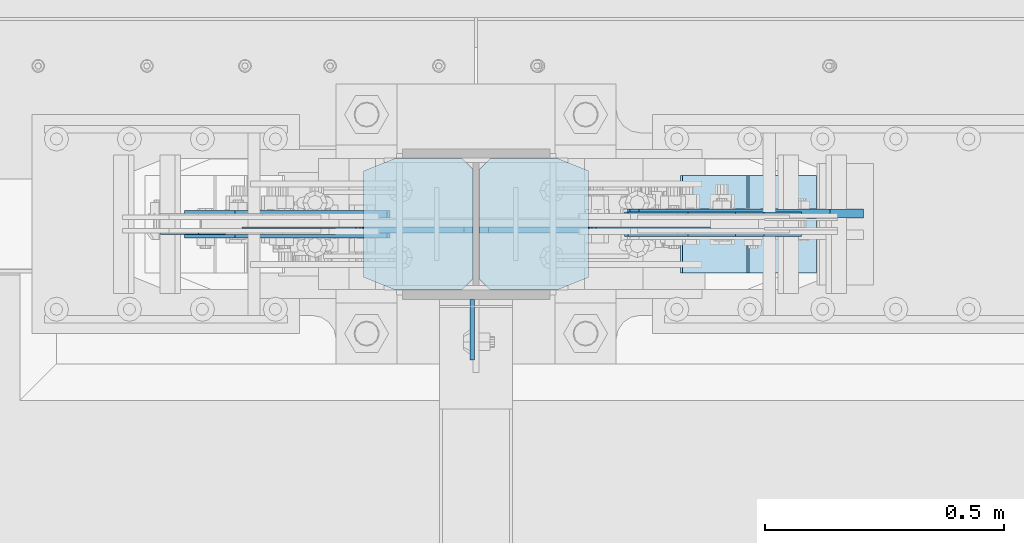
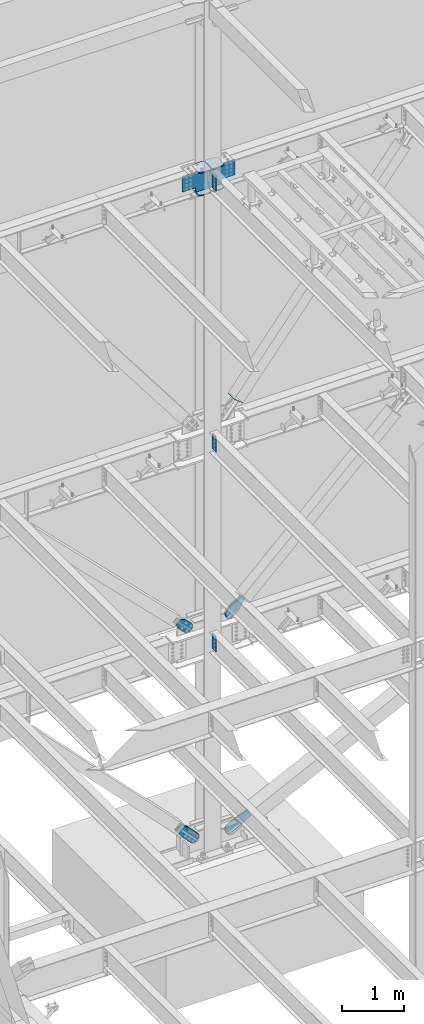
# One storey, part 1073 of 1179: 17 plates, 9 elements without a shape of their own.
"""IFC2X3 building model written with IfcOpenShell, lengths in millimetres."""

from ifc_helpers import new_model, si_unit, frame, origin_with_axes, place, context, subcontext, project, spatial, faceted_brep, material, type_object, element, aggregate, save


model = new_model("IFC2X3")

# Units and contexts
model_context = context("Model", 3, precision=1e-05, world=origin_with_axes())
body_context = subcontext(model_context, "Body", "Model", "MODEL_VIEW")
ifc_project = project(units=[si_unit("LENGTHUNIT", "METRE", prefix="MILLI"), si_unit("AREAUNIT", "SQUARE_METRE"), si_unit("VOLUMEUNIT", "CUBIC_METRE"), si_unit("MASSUNIT", "GRAM", prefix="KILO"), si_unit("TIMEUNIT", "SECOND"), si_unit("PLANEANGLEUNIT", "RADIAN"), si_unit("SOLIDANGLEUNIT", "STERADIAN"), si_unit("THERMODYNAMICTEMPERATUREUNIT", "DEGREE_CELSIUS"), si_unit("LUMINOUSINTENSITYUNIT", "LUMEN")], contexts=[model_context])

# Site, building, storey
site_placement = place(None, origin_with_axes())
site = spatial("IfcSite", under=ifc_project, at=site_placement, CompositionType="ELEMENT")
building_placement = place(site_placement, origin_with_axes())
building = spatial("IfcBuilding", under=site, at=building_placement, Name="Undefined", CompositionType="ELEMENT")
storey_placement = place(building_placement, origin_with_axes())
storey = spatial("IfcBuildingStorey", under=building, at=storey_placement, Name="Undefined", CompositionType="ELEMENT", Elevation=0.0)

# Assembly, plates
assembly_1_placement = place(storey_placement, origin_with_axes())
assembly_1 = element("IfcElementAssembly", 1, at=assembly_1_placement, inside=storey, Name="COLUMN", AssemblyPlace="NOTDEFINED", PredefinedType="RIGID_FRAME")
ifc_material_1 = material(Name="STEEL/A36")
plate_type_1 = type_object("IfcPlateType", PredefinedType="NOTDEFINED")
plate_1_placement = place(assembly_1_placement, frame((8272.4625, 41041.6375, 13080.9999983942), z_axis=(0.0, -1.0, 0.0), x_axis=(0.0, 0.0, -1.0)))
plate_1 = element("IfcPlate", 2, at=plate_1_placement, type_object=plate_type_1, material=ifc_material_1, Name="PLATE", context=body_context, shape_type="Brep", body=[
    faceted_brep([(0.0, -4.76249999999709, 0.0), (0.0, -4.76249999999709, 127.0), (0.0, 4.76249999999709, 127.0), (0.0, 4.76249999999709, 0.0), (304.799999999999, -4.76249999999982, 127.0), (304.799999999999, 4.76249999999982, 127.0), (304.799987792969, -4.76250000000073, 0.0), (304.799987792969, 4.76250000000073, 0.0)], [[[0, 1, 2, 3]], [[2, 1, 4, 5]], [[4, 6, 7, 5]], [[6, 0, 3, 7]], [[5, 7, 3, 2]], [[6, 4, 1, 0]]]),
])
plate_2_placement = place(assembly_1_placement, frame((8272.4625, 41041.6375, 7975.59999886453), z_axis=(0.0, -1.0, 0.0), x_axis=(0.0, 0.0, -1.0)))
plate_2 = element("IfcPlate", 3, at=plate_2_placement, type_object=plate_type_1, material=ifc_material_1, Name="PLATE", context=body_context, shape_type="Brep", body=[
    faceted_brep([(0.0, -4.76249999999709, 0.0), (0.0, -4.76249999999709, 127.0), (0.0, 4.76249999999709, 127.0), (0.0, 4.76249999999709, 0.0), (304.799999999999, -4.76249999999982, 127.0), (304.799999999999, 4.76249999999982, 127.0), (304.799987792969, -4.76250000000073, 0.0), (304.799987792969, 4.76250000000073, 0.0)], [[[0, 1, 2, 3]], [[2, 1, 4, 5]], [[4, 6, 7, 5]], [[6, 0, 3, 7]], [[5, 7, 3, 2]], [[6, 4, 1, 0]]]),
])
plate_3_placement = place(assembly_1_placement, frame((8272.46241496891, 41041.6375000794, 4063.99999886453), z_axis=(0.0, -1.0, 0.0), x_axis=(0.0, 0.0, -1.0)))
plate_3 = element("IfcPlate", 4, at=plate_3_placement, type_object=plate_type_1, material=ifc_material_1, Name="PLATE", context=body_context, shape_type="Brep", body=[
    faceted_brep([(0.0, -4.76249999999709, 0.0), (0.0, -4.76249999999709, 127.0), (0.0, 4.76249999999709, 127.0), (0.0, 4.76249999999709, 0.0), (304.799999999999, -4.76249999999982, 127.0), (304.799999999999, 4.76249999999982, 127.0), (304.799987792969, -4.76250000000073, 0.0), (304.799987792969, 4.76250000000073, 0.0)], [[[0, 1, 2, 3]], [[2, 1, 4, 5]], [[4, 6, 7, 5]], [[6, 0, 3, 7]], [[5, 7, 3, 2]], [[6, 4, 1, 0]]]),
])

# Assembly, plate
assembly_2_placement = place(storey_placement, origin_with_axes())
assembly_2 = element("IfcElementAssembly", 5, at=assembly_2_placement, inside=storey, Name="Plate", AssemblyPlace="NOTDEFINED", PredefinedType="RIGID_FRAME")
plate_type_2 = type_object("IfcPlateType", PredefinedType="NOTDEFINED")
plate_4_placement = place(assembly_2_placement, frame((8868.55888202994, 41097.2, 8315.96638428484), z_axis=(-0.782937860640372, 0.0, 0.62209991671425), x_axis=(0.0, 1.0, 0.0)))
plate_4 = element("IfcPlate", 6, at=plate_4_placement, type_object=plate_type_2, material=ifc_material_1, Name="Plate", context=body_context, shape_type="Brep", body=[
    faceted_brep([(0.0, -3.17500000000109, 0.0), (0.0, -3.17500000000291, 203.200000000368), (0.0, 3.17499999998836, 203.200000000361), (0.0, 3.17500000000109, 7.27595761418343e-12), (203.199999999997, -3.17500000000291, 203.200000000368), (203.199999999997, 3.17499999998836, 203.200000000361), (203.199999999997, -3.17499999999927, 3.63797880709171e-12), (203.199999999997, 3.17499999999382, -3.63797880709171e-12)], [[[0, 1, 2, 3]], [[1, 4, 5, 2]], [[4, 6, 7, 5]], [[6, 0, 3, 7]], [[5, 7, 3, 2]], [[6, 4, 1, 0]]]),
])
aggregate(assembly_2, [plate_4])

assembly_3_placement = place(storey_placement, origin_with_axes())
assembly_3 = element("IfcElementAssembly", 7, at=assembly_3_placement, inside=storey, Name="Plate", AssemblyPlace="NOTDEFINED", PredefinedType="RIGID_FRAME")
plate_5_placement = place(assembly_3_placement, frame((8988.59916071883, 41097.2, 4364.27515941602), z_axis=(-0.691222646058185, 0.0, 0.722641857060828), x_axis=(0.0, 1.0, 0.0)))
plate_5 = element("IfcPlate", 8, at=plate_5_placement, type_object=plate_type_2, material=ifc_material_1, Name="Plate", context=body_context, shape_type="Brep", body=[
    faceted_brep([(0.0, -3.17500000000109, 0.0), (0.0, -3.17500000000291, 203.200000000368), (0.0, 3.17499999998836, 203.200000000361), (0.0, 3.17500000000109, 7.27595761418343e-12), (203.199999999997, -3.17500000000291, 203.200000000368), (203.199999999997, 3.17499999998836, 203.200000000361), (203.199999999997, -3.17499999999927, 3.63797880709171e-12), (203.199999999997, 3.17499999999382, -3.63797880709171e-12)], [[[0, 1, 2, 3]], [[1, 4, 5, 2]], [[4, 6, 7, 5]], [[6, 0, 3, 7]], [[5, 7, 3, 2]], [[6, 4, 1, 0]]]),
])
aggregate(assembly_3, [plate_5])

# Plate
ifc_material_2 = material(Name="STEEL/A572-GR.50")
plate_type_3 = type_object("IfcPlateType", PredefinedType="NOTDEFINED")
plate_6_placement = place(assembly_1_placement, frame((8515.35, 41062.275, 12663.4875), z_axis=(0.0, 1.0, 0.0), x_axis=(-1.0, 0.0, 0.0)))
plate_6 = element("IfcPlate", 9, at=plate_6_placement, type_object=plate_type_3, material=ifc_material_2, Name="PLATE", context=body_context, shape_type="Brep", body=[
    faceted_brep([(0.0, -11.1125000000002, 25.3999996185303), (0.0, -11.1125000000002, 247.650000381473), (0.0, 11.1125000000002, 247.650000381473), (0.0, 11.1125000000002, 25.3999996185303), (63.5, -11.1125000000002, 273.050000000003), (63.5, 11.1125000000002, 273.050000000003), (206.374999618529, -11.1125000000002, 273.050000000003), (206.374999618529, 11.1125000000002, 273.050000000003), (228.599999999999, -11.1125000000002, 250.824999618533), (228.599999999999, 11.1125000000002, 250.824999618533), (228.599999999999, -11.1125000000002, 22.2250003814697), (228.599999999999, 11.1125000000002, 22.2250003814697), (206.374999618529, -11.1125000000002, 0.0), (206.374999618529, 11.1125000000002, 0.0), (63.5, -11.1125000000002, 0.0), (63.5, 11.1125000000002, 0.0)], [[[0, 1, 2, 3]], [[1, 4, 5, 2]], [[4, 6, 7, 5]], [[6, 8, 9, 7]], [[8, 10, 11, 9]], [[10, 12, 13, 11]], [[12, 14, 15, 13]], [[14, 0, 3, 15]], [[5, 7, 9, 11, 13, 15, 3, 2]], [[14, 12, 10, 8, 6, 4, 1, 0]]]),
])

plate_7_placement = place(assembly_1_placement, frame((8515.35, 41062.275, 13107.9875), z_axis=(0.0, 1.0, 0.0), x_axis=(-1.0, 0.0, 0.0)))
plate_7 = element("IfcPlate", 10, at=plate_7_placement, type_object=plate_type_3, material=ifc_material_2, Name="PLATE", context=body_context, shape_type="Brep", body=[
    faceted_brep([(0.0, -11.1125000000002, 25.3999996185303), (0.0, -11.1125000000002, 247.650000381473), (0.0, 11.1125000000002, 247.650000381473), (0.0, 11.1125000000002, 25.3999996185303), (63.5, -11.1125000000002, 273.050000000003), (63.5, 11.1125000000002, 273.050000000003), (206.374999618529, -11.1125000000002, 273.050000000003), (206.374999618529, 11.1125000000002, 273.050000000003), (228.599999999999, -11.1125000000002, 250.824999618533), (228.599999999999, 11.1125000000002, 250.824999618533), (228.599999999999, -11.1125000000002, 22.2250003814697), (228.599999999999, 11.1125000000002, 22.2250003814697), (206.374999618529, -11.1125000000002, 0.0), (206.374999618529, 11.1125000000002, 0.0), (63.5, -11.1125000000002, 0.0), (63.5, 11.1125000000002, 0.0)], [[[0, 1, 2, 3]], [[1, 4, 5, 2]], [[4, 6, 7, 5]], [[6, 8, 9, 7]], [[8, 10, 11, 9]], [[10, 12, 13, 11]], [[12, 14, 15, 13]], [[14, 0, 3, 15]], [[5, 7, 9, 11, 13, 15, 3, 2]], [[14, 12, 10, 8, 6, 4, 1, 0]]]),
])

plate_8_placement = place(assembly_1_placement, frame((8045.45, 41335.325, 12663.4875), z_axis=(0.0, -1.0, 0.0), x_axis=(1.0, 0.0, 0.0)))
plate_8 = element("IfcPlate", 11, at=plate_8_placement, type_object=plate_type_3, material=ifc_material_2, Name="PLATE", context=body_context, shape_type="Brep", body=[
    faceted_brep([(0.0, -11.1125000000002, 25.3999996185303), (0.0, -11.1125000000002, 247.650000381473), (0.0, 11.1125000000002, 247.650000381473), (0.0, 11.1125000000002, 25.3999996185303), (63.5, -11.1125000000002, 273.050000000003), (63.5, 11.1125000000002, 273.050000000003), (206.374999618529, -11.1125000000002, 273.050000000003), (206.374999618529, 11.1125000000002, 273.050000000003), (228.599999999999, -11.1125000000002, 250.824999618533), (228.599999999999, 11.1125000000002, 250.824999618533), (228.599999999999, -11.1125000000002, 22.2250003814697), (228.599999999999, 11.1125000000002, 22.2250003814697), (206.374999618529, -11.1125000000002, 0.0), (206.374999618529, 11.1125000000002, 0.0), (63.5, -11.1125000000002, 0.0), (63.5, 11.1125000000002, 0.0)], [[[0, 1, 2, 3]], [[1, 4, 5, 2]], [[4, 6, 7, 5]], [[6, 8, 9, 7]], [[8, 10, 11, 9]], [[10, 12, 13, 11]], [[12, 14, 15, 13]], [[14, 0, 3, 15]], [[5, 7, 9, 11, 13, 15, 3, 2]], [[14, 12, 10, 8, 6, 4, 1, 0]]]),
])

plate_9_placement = place(assembly_1_placement, frame((8045.45, 41335.325, 13107.9875), z_axis=(0.0, -1.0, 0.0), x_axis=(1.0, 0.0, 0.0)))
plate_9 = element("IfcPlate", 12, at=plate_9_placement, type_object=plate_type_3, material=ifc_material_2, Name="PLATE", context=body_context, shape_type="Brep", body=[
    faceted_brep([(0.0, -11.1125000000002, 25.3999996185303), (0.0, -11.1125000000002, 247.650000381473), (0.0, 11.1125000000002, 247.650000381473), (0.0, 11.1125000000002, 25.3999996185303), (63.5, -11.1125000000002, 273.050000000003), (63.5, 11.1125000000002, 273.050000000003), (206.374999618529, -11.1125000000002, 273.050000000003), (206.374999618529, 11.1125000000002, 273.050000000003), (228.599999999999, -11.1125000000002, 250.824999618533), (228.599999999999, 11.1125000000002, 250.824999618533), (228.599999999999, -11.1125000000002, 22.2250003814697), (228.599999999999, 11.1125000000002, 22.2250003814697), (206.374999618529, -11.1125000000002, 0.0), (206.374999618529, 11.1125000000002, 0.0), (63.5, -11.1125000000002, 0.0), (63.5, 11.1125000000002, 0.0)], [[[0, 1, 2, 3]], [[1, 4, 5, 2]], [[4, 6, 7, 5]], [[6, 8, 9, 7]], [[8, 10, 11, 9]], [[10, 12, 13, 11]], [[12, 14, 15, 13]], [[14, 0, 3, 15]], [[5, 7, 9, 11, 13, 15, 3, 2]], [[14, 12, 10, 8, 6, 4, 1, 0]]]),
])

plate_type_4 = type_object("IfcPlateType", PredefinedType="NOTDEFINED")
plate_10_placement = place(assembly_1_placement, frame((8286.75, 41186.89375, 12693.65), z_axis=(0.707106781186573, 0.0, 0.707106781186522), x_axis=(0.707106781186522, 0.0, -0.707106781186573)))
plate_10 = element("IfcPlate", 13, at=plate_10_placement, type_object=plate_type_4, material=ifc_material_2, Name="PLATE", context=body_context, shape_type="Brep", body=[
    faceted_brep([(0.0, -6.34999999999854, 0.0), (-271.652749686205, -6.35000000000036, 271.652745638487), (-271.652749686205, 6.35000000000036, 271.652745638487), (0.0, 6.34999999999854, 0.0), (-271.652749686187, -6.35000000000036, 298.59351380097), (-271.652749686187, 6.35000000000036, 298.59351380097), (-123.478521665553, -6.34999999999854, 446.767742022512), (-123.478521665553, 6.34999999999854, 446.767742022512), (-121.233457365147, -6.34999999999854, 444.522677722911), (-121.233457365147, 6.34999999999854, 444.522677722911), (-112.993104428839, -6.34999999999854, 439.016649921954), (-112.993104428839, 6.34999999999854, 439.016649921954), (-103.272945392747, -6.34999999999854, 437.083190076777), (-103.272945392747, 6.34999999999854, 437.083190076777), (-93.5527863566531, -6.34999999999854, 439.016649921954), (-93.5527863566531, 6.34999999999854, 439.016649921954), (-85.3124334203458, -6.34999999999854, 444.522677722913), (-85.3124334203458, 6.34999999999854, 444.522677722913), (76.3321770282328, -6.34999999999854, 606.167288171488), (76.3321770282328, 6.34999999999854, 606.167288171488), (291.858323933965, -6.34999999999854, 390.641141265758), (291.858323933965, 6.34999999999854, 390.641141265758), (130.213713485389, -6.34999999999854, 228.996530817178), (130.213713485389, 6.34999999999854, 228.996530817178), (124.707685684432, -6.34999999999854, 220.756177880869), (124.707685684432, 6.34999999999854, 220.756177880869), (122.774225839255, -6.34999999999854, 211.036018844778), (122.774225839255, 6.34999999999854, 211.036018844778), (124.707685684432, -6.34999999999854, 201.315859808683), (124.707685684432, 6.34999999999854, 201.315859808683), (130.21371348539, -6.34999999999854, 193.075506872374), (130.21371348539, 6.34999999999854, 193.075506872374), (175.114994360907, -6.34999999999854, 148.174225997692), (175.114994360907, 6.34999999999854, 148.174225997692), (26.9407683631471, -6.34999999999854, -6.91215973347425e-11), (26.9407683631471, 6.34999999999854, -6.91215973347425e-11)], [[[0, 1, 2, 3]], [[1, 4, 5, 2]], [[4, 6, 7, 5]], [[6, 8, 9, 7]], [[8, 10, 11, 9]], [[10, 12, 13, 11]], [[12, 14, 15, 13]], [[14, 16, 17, 15]], [[16, 18, 19, 17]], [[18, 20, 21, 19]], [[20, 22, 23, 21]], [[22, 24, 25, 23]], [[24, 26, 27, 25]], [[26, 28, 29, 27]], [[28, 30, 31, 29]], [[30, 32, 33, 31]], [[32, 34, 35, 33]], [[34, 0, 3, 35]], [[5, 7, 9, 11, 13, 15, 17, 19, 21, 23, 25, 27, 29, 31, 33, 35, 3, 2]], [[34, 32, 30, 28, 26, 24, 22, 20, 18, 16, 14, 12, 10, 8, 6, 4, 1, 0]]]),
])

plate_11_placement = place(assembly_1_placement, frame((8274.04999929908, 41186.89375, 12693.65), z_axis=(-0.707106781186532, 0.0, 0.707106781186563), x_axis=(-0.707106781186564, 0.0, -0.707106781186531)))
plate_11 = element("IfcPlate", 14, at=plate_11_placement, type_object=plate_type_4, material=ifc_material_2, Name="PLATE", context=body_context, shape_type="Brep", body=[
    faceted_brep([(0.0, -6.34999999999854, 0.0), (-271.652749686205, -6.35000000000036, 271.652745638487), (-271.652749686205, 6.35000000000036, 271.652745638487), (0.0, 6.34999999999854, 0.0), (-271.652749686187, -6.35000000000036, 298.59351380097), (-271.652749686187, 6.35000000000036, 298.59351380097), (-123.478521665553, -6.34999999999854, 446.767742022512), (-123.478521665553, 6.34999999999854, 446.767742022512), (-121.233457365147, -6.34999999999854, 444.522677722911), (-121.233457365147, 6.34999999999854, 444.522677722911), (-112.993104428839, -6.34999999999854, 439.016649921954), (-112.993104428839, 6.34999999999854, 439.016649921954), (-103.272945392747, -6.34999999999854, 437.083190076777), (-103.272945392747, 6.34999999999854, 437.083190076777), (-93.5527863566531, -6.34999999999854, 439.016649921954), (-93.5527863566531, 6.34999999999854, 439.016649921954), (-85.3124334203458, -6.34999999999854, 444.522677722913), (-85.3124334203458, 6.34999999999854, 444.522677722913), (76.3321770282328, -6.34999999999854, 606.167288171488), (76.3321770282328, 6.34999999999854, 606.167288171488), (291.858323933965, -6.34999999999854, 390.641141265758), (291.858323933965, 6.34999999999854, 390.641141265758), (130.213713485389, -6.34999999999854, 228.996530817178), (130.213713485389, 6.34999999999854, 228.996530817178), (124.707685684432, -6.34999999999854, 220.756177880869), (124.707685684432, 6.34999999999854, 220.756177880869), (122.774225839255, -6.34999999999854, 211.036018844778), (122.774225839255, 6.34999999999854, 211.036018844778), (124.707685684432, -6.34999999999854, 201.315859808683), (124.707685684432, 6.34999999999854, 201.315859808683), (130.21371348539, -6.34999999999854, 193.075506872374), (130.21371348539, 6.34999999999854, 193.075506872374), (175.114994360907, -6.34999999999854, 148.174225997692), (175.114994360907, 6.34999999999854, 148.174225997692), (26.9407683631471, -6.34999999999854, -6.91215973347425e-11), (26.9407683631471, 6.34999999999854, -6.91215973347425e-11)], [[[0, 1, 2, 3]], [[1, 4, 5, 2]], [[4, 6, 7, 5]], [[6, 8, 9, 7]], [[8, 10, 11, 9]], [[10, 12, 13, 11]], [[12, 14, 15, 13]], [[14, 16, 17, 15]], [[16, 18, 19, 17]], [[18, 20, 21, 19]], [[20, 22, 23, 21]], [[22, 24, 25, 23]], [[24, 26, 27, 25]], [[26, 28, 29, 27]], [[28, 30, 31, 29]], [[30, 32, 33, 31]], [[32, 34, 35, 33]], [[34, 0, 3, 35]], [[5, 7, 9, 11, 13, 15, 17, 19, 21, 23, 25, 27, 29, 31, 33, 35, 3, 2]], [[34, 32, 30, 28, 26, 24, 22, 20, 18, 16, 14, 12, 10, 8, 6, 4, 1, 0]]]),
])

aggregate(assembly_1, [plate_1, plate_6, plate_7, plate_10, plate_8, plate_9, plate_11, plate_2, plate_3])

# Assembly, plate
assembly_4_placement = place(storey_placement, origin_with_axes())
assembly_4 = element("IfcElementAssembly", 15, at=assembly_4_placement, inside=storey, AssemblyPlace="NOTDEFINED", PredefinedType="RIGID_FRAME")
plate_type_5 = type_object("IfcPlateType", PredefinedType="NOTDEFINED")
plate_12_placement = place(assembly_4_placement, frame((8899.78362483428, 41217.85, 4342.29501119751), z_axis=(-0.691222646058185, 0.0, 0.722641857060828), x_axis=(0.722641857060828, 0.0, 0.691222646058184)))
plate_12 = element("IfcPlate", 16, at=plate_12_placement, type_object=plate_type_5, material=ifc_material_1, context=body_context, shape_type="Brep", body=[
    faceted_brep([(0.0, -6.34999999999854, 0.0), (-101.599999999963, -6.34999999999854, -37.5700345970108), (-101.599999999963, 6.34999999999854, -37.5700345970108), (0.0, 6.34999999999854, 0.0), (-245.369242323884, -6.34999999999854, -37.5700345970945), (-245.369242323884, 6.34999999999854, -37.5700345970945), (-281.212328723803, -6.34999999999854, -30.4404014271258), (-281.212328723803, 6.34999999999854, -30.4404014271258), (-311.598630137756, -6.34999999999854, -10.1369239370142), (-311.598630137756, 6.34999999999854, -10.1369239370142), (-331.902107627997, -6.34999999999854, 20.24937747687), (-331.902107627997, 6.34999999999854, 20.24937747687), (-339.031740798124, -6.34999999999854, 56.0924669287269), (-339.031740798124, 6.34999999999854, 56.0924669287269), (-331.902107628228, -6.34999999999854, 91.9355533287926), (-331.902107628228, 6.34999999999854, 91.9355533287926), (-311.598630138099, -6.34999999999854, 122.321854742866), (-311.598630138099, 6.34999999999854, 122.321854742866), (-281.212328724136, -6.34999999999854, 142.625332233139), (-281.212328724136, 6.34999999999854, 142.625332233139), (-245.36924079839, -6.34999999999854, 149.754965403199), (-245.36924079839, 6.34999999999854, 149.754965403199), (-101.600000000685, -6.34999999999854, 149.75496540329), (-101.600000000685, 6.34999999999854, 149.75496540329), (-4.35647962149233e-10, -6.34999999999854, 112.184930806416), (-4.35647962149233e-10, 6.34999999999854, 112.184930806416), (82.5499999996491, -6.34999999999854, 112.184930806461), (82.5499999996491, 6.34999999999854, 112.184930806461), (82.550000000203, -6.34999999999854, 1.2732925824821e-10), (82.550000000203, 6.34999999999854, 1.2732925824821e-10)], [[[0, 1, 2, 3]], [[1, 4, 5, 2]], [[4, 6, 7, 5]], [[6, 8, 9, 7]], [[8, 10, 11, 9]], [[10, 12, 13, 11]], [[12, 14, 15, 13]], [[14, 16, 17, 15]], [[16, 18, 19, 17]], [[18, 20, 21, 19]], [[20, 22, 23, 21]], [[22, 24, 25, 23]], [[24, 26, 27, 25]], [[26, 28, 29, 27]], [[28, 0, 3, 29]], [[5, 7, 9, 11, 13, 15, 17, 19, 21, 23, 25, 27, 29, 3, 2]], [[28, 26, 24, 22, 20, 18, 16, 14, 12, 10, 8, 6, 4, 1, 0]]]),
])
aggregate(assembly_4, [plate_12])

assembly_5_placement = place(storey_placement, origin_with_axes())
assembly_5 = element("IfcElementAssembly", 17, at=assembly_5_placement, inside=storey, AssemblyPlace="NOTDEFINED", PredefinedType="RIGID_FRAME")
plate_13_placement = place(assembly_5_placement, frame((8899.78362483428, 41179.75, 4342.29501119751), z_axis=(-0.691222646058185, 0.0, 0.722641857060828), x_axis=(0.722641857060828, 0.0, 0.691222646058184)))
plate_13 = element("IfcPlate", 18, at=plate_13_placement, type_object=plate_type_5, material=ifc_material_1, context=body_context, shape_type="Brep", body=[
    faceted_brep([(0.0, -6.34999999999854, 0.0), (-101.599999999963, -6.34999999999854, -37.5700345970108), (-101.599999999963, 6.34999999999854, -37.5700345970108), (0.0, 6.34999999999854, 0.0), (-245.369242323884, -6.34999999999854, -37.5700345970945), (-245.369242323884, 6.34999999999854, -37.5700345970945), (-281.212328723803, -6.34999999999854, -30.4404014271258), (-281.212328723803, 6.34999999999854, -30.4404014271258), (-311.598630137756, -6.34999999999854, -10.1369239370142), (-311.598630137756, 6.34999999999854, -10.1369239370142), (-331.902107627997, -6.34999999999854, 20.24937747687), (-331.902107627997, 6.34999999999854, 20.24937747687), (-339.031740798124, -6.34999999999854, 56.0924669287269), (-339.031740798124, 6.34999999999854, 56.0924669287269), (-331.902107628228, -6.34999999999854, 91.9355533287926), (-331.902107628228, 6.34999999999854, 91.9355533287926), (-311.598630138099, -6.34999999999854, 122.321854742866), (-311.598630138099, 6.34999999999854, 122.321854742866), (-281.212328724136, -6.34999999999854, 142.625332233139), (-281.212328724136, 6.34999999999854, 142.625332233139), (-245.36924079839, -6.34999999999854, 149.754965403199), (-245.36924079839, 6.34999999999854, 149.754965403199), (-101.600000000685, -6.34999999999854, 149.75496540329), (-101.600000000685, 6.34999999999854, 149.75496540329), (-4.35647962149233e-10, -6.34999999999854, 112.184930806416), (-4.35647962149233e-10, 6.34999999999854, 112.184930806416), (82.5499999996491, -6.34999999999854, 112.184930806461), (82.5499999996491, 6.34999999999854, 112.184930806461), (82.550000000203, -6.34999999999854, 1.2732925824821e-10), (82.550000000203, 6.34999999999854, 1.2732925824821e-10)], [[[0, 1, 2, 3]], [[1, 4, 5, 2]], [[4, 6, 7, 5]], [[6, 8, 9, 7]], [[8, 10, 11, 9]], [[10, 12, 13, 11]], [[12, 14, 15, 13]], [[14, 16, 17, 15]], [[16, 18, 19, 17]], [[18, 20, 21, 19]], [[20, 22, 23, 21]], [[22, 24, 25, 23]], [[24, 26, 27, 25]], [[26, 28, 29, 27]], [[28, 0, 3, 29]], [[5, 7, 9, 11, 13, 15, 17, 19, 21, 23, 25, 27, 29, 3, 2]], [[28, 26, 24, 22, 20, 18, 16, 14, 12, 10, 8, 6, 4, 1, 0]]]),
])
aggregate(assembly_5, [plate_13])

assembly_6_placement = place(storey_placement, origin_with_axes())
assembly_6 = element("IfcElementAssembly", 19, at=assembly_6_placement, inside=storey, AssemblyPlace="NOTDEFINED", PredefinedType="RIGID_FRAME")
plate_14_placement = place(assembly_6_placement, frame((7700.73462762327, 41182.925, 4484.45040012886), z_axis=(-0.705959813968941, 0.0, -0.708251890968841), x_axis=(0.708251890968839, 0.0, -0.705959813968942)))
plate_14 = element("IfcPlate", 20, at=plate_14_placement, type_object=plate_type_5, material=ifc_material_1, context=body_context, shape_type="Brep", body=[
    faceted_brep([(0.0, -6.34999999999854, 0.0), (-4.35647962149233e-10, -6.34999999999854, 112.184930806416), (-4.35647962149233e-10, 6.34999999999854, 112.184930806416), (0.0, 6.34999999999854, 0.0), (82.5499999996491, -6.34999999999854, 112.184930806461), (82.5499999996491, 6.34999999999854, 112.184930806461), (184.149999999618, -6.34999999999854, 149.75496540347), (184.149999999618, 6.34999999999854, 149.75496540347), (327.919242323534, -6.34999999999854, 149.754965403559), (327.919242323534, 6.34999999999854, 149.754965403559), (363.762328723451, -6.34999999999854, 142.625332233587), (363.762328723451, 6.34999999999854, 142.625332233587), (394.148630137406, -6.34999999999854, 122.321854743475), (394.148630137406, 6.34999999999854, 122.321854743475), (414.452107627645, -6.34999999999854, 91.9355533295929), (414.452107627645, 6.34999999999854, 91.9355533295929), (421.581740797776, -6.34999999999854, 56.0924638777396), (421.581740797776, 6.34999999999854, 56.0924638777396), (414.452107627878, -6.34999999999854, 20.2493774776722), (414.452107627878, 6.34999999999854, 20.2493774776722), (394.14863013775, -6.34999999999854, -10.1369239363994), (394.14863013775, 6.34999999999854, -10.1369239363994), (363.762328723789, -6.34999999999854, -30.4404014266784), (363.762328723789, 6.34999999999854, -30.4404014266784), (327.919240798041, -6.34999999999854, -37.570034596738), (327.919240798041, 6.34999999999854, -37.570034596738), (184.150000000338, -6.34999999999854, -37.5700345968289), (184.150000000338, 6.34999999999854, -37.5700345968289), (82.550000000203, -6.34999999999854, 1.2732925824821e-10), (82.550000000203, 6.34999999999854, 1.2732925824821e-10)], [[[0, 1, 2, 3]], [[1, 4, 5, 2]], [[4, 6, 7, 5]], [[6, 8, 9, 7]], [[8, 10, 11, 9]], [[10, 12, 13, 11]], [[12, 14, 15, 13]], [[14, 16, 17, 15]], [[16, 18, 19, 17]], [[18, 20, 21, 19]], [[20, 22, 23, 21]], [[22, 24, 25, 23]], [[24, 26, 27, 25]], [[26, 28, 29, 27]], [[28, 0, 3, 29]], [[5, 7, 9, 11, 13, 15, 17, 19, 21, 23, 25, 27, 29, 3, 2]], [[28, 26, 24, 22, 20, 18, 16, 14, 12, 10, 8, 6, 4, 1, 0]]]),
])
aggregate(assembly_6, [plate_14])

assembly_7_placement = place(storey_placement, origin_with_axes())
assembly_7 = element("IfcElementAssembly", 21, at=assembly_7_placement, inside=storey, AssemblyPlace="NOTDEFINED", PredefinedType="RIGID_FRAME")
plate_type_6 = type_object("IfcPlateType", PredefinedType="NOTDEFINED")
plate_15_placement = place(assembly_7_placement, frame((9015.15683481444, 41221.025, 58.9959651378661), z_axis=(-0.443172292794208, 0.0, 0.896436455583732), x_axis=(0.896436455583732, 0.0, 0.443172292794209)))
plate_15 = element("IfcPlate", 22, at=plate_15_placement, type_object=plate_type_6, material=ifc_material_1, context=body_context, shape_type="Brep", body=[
    faceted_brep([(0.0, -9.52499999999964, 0.0), (-101.599999999631, -9.52500000000146, -17.6403935121948), (-101.599999999631, 9.52500000000146, -17.6403935121948), (0.0, 9.52499999999964, 0.0), (-320.279297669141, -9.52500000000146, -17.6403935121907), (-320.279297669141, 9.52500000000146, -17.6403935121907), (-357.337405134735, -9.52500000000146, -10.2690776255863), (-357.337405134735, 9.52500000000146, -10.2690776255863), (-388.753751671267, -9.52500000000146, 10.7226540116294), (-388.753751671267, 9.52500000000146, 10.7226540116294), (-409.745483308434, -9.52500000000146, 42.1390005482076), (-409.745483308434, 9.52500000000146, 42.1390005482076), (-417.116799194993, -9.52500000000146, 79.1971049621179), (-417.116799194993, 9.52500000000146, 79.1971049621179), (-409.745483308381, -9.52500000000146, 116.255212427672), (-409.745483308381, 9.52500000000146, 116.255212427672), (-388.753751671213, -9.52500000000146, 147.671558964167), (-388.753751671213, 9.52500000000146, 147.671558964167), (-357.337405134718, -9.52500000000146, 168.663290601317), (-357.337405134718, 9.52500000000146, 168.663290601317), (-320.279299195261, -9.52500000000146, 176.034606487895), (-320.279299195261, 9.52500000000146, 176.034606487895), (-101.599999999431, -9.52500000000146, 176.034606487892), (-101.599999999431, 9.52500000000146, 176.034606487892), (2.34649633057415e-10, -9.52500000000146, 158.394212975713), (2.34649633057415e-10, 9.52500000000146, 158.394212975713), (82.5499999999411, -9.52500000000146, 158.394212975733), (82.5499999999411, 9.52500000000146, 158.394212975733), (82.5499999997119, -9.52500000000146, 1.81898940354586e-11), (82.5499999997119, 9.52500000000146, 1.81898940354586e-11)], [[[0, 1, 2, 3]], [[1, 4, 5, 2]], [[4, 6, 7, 5]], [[6, 8, 9, 7]], [[8, 10, 11, 9]], [[10, 12, 13, 11]], [[12, 14, 15, 13]], [[14, 16, 17, 15]], [[16, 18, 19, 17]], [[18, 20, 21, 19]], [[20, 22, 23, 21]], [[22, 24, 25, 23]], [[24, 26, 27, 25]], [[26, 28, 29, 27]], [[28, 0, 3, 29]], [[5, 7, 9, 11, 13, 15, 17, 19, 21, 23, 25, 27, 29, 3, 2]], [[28, 26, 24, 22, 20, 18, 16, 14, 12, 10, 8, 6, 4, 1, 0]]]),
])
aggregate(assembly_7, [plate_15])

assembly_8_placement = place(storey_placement, origin_with_axes())
assembly_8 = element("IfcElementAssembly", 23, at=assembly_8_placement, inside=storey, AssemblyPlace="NOTDEFINED", PredefinedType="RIGID_FRAME")
plate_type_7 = type_object("IfcPlateType", PredefinedType="NOTDEFINED")
plate_16_placement = place(assembly_8_placement, frame((7777.06452172845, 41219.4375, 408.171567701832), z_axis=(-0.717593116036186, 0.0, -0.696462576035121), x_axis=(0.696462576035121, 0.0, -0.717593116036186)))
plate_16 = element("IfcPlate", 24, at=plate_16_placement, type_object=plate_type_7, material=ifc_material_1, context=body_context, shape_type="Brep", body=[
    faceted_brep([(0.0, -7.9375, 0.0), (-8.00355337560177e-11, -7.9375, 146.904840309817), (-8.00355337560177e-11, 7.9375, 146.904840309817), (0.0, 7.9375, 0.0), (82.5499999998137, -7.9375, 146.90484031055), (82.5499999998137, 7.9375, 146.90484031055), (184.150000000214, -7.9375, 168.702420155054), (184.150000000214, 7.9375, 168.702420155054), (403.471138850085, -7.9375, 168.70242015493), (403.471138850085, 7.9375, 168.70242015493), (439.921735782846, -7.9375, 161.451945626626), (439.921735782846, 7.9375, 161.451945626626), (470.823059758064, -7.9375, 140.804341062974), (470.823059758064, 7.9375, 140.804341062974), (491.470664321725, -7.9375, 109.903017087783), (491.470664321725, 7.9375, 109.903017087783), (498.721138850011, -7.9375, 73.4524201549993), (498.721138850011, 7.9375, 73.4524201549993), (491.470664321694, -7.9375, 37.001823222241), (491.470664321694, 7.9375, 37.001823222241), (470.82305975797, -7.9375, 6.10049924700979), (470.82305975797, 7.9375, 6.10049924700979), (439.921735782676, -7.9375, -14.5471053166548), (439.921735782676, 7.9375, -14.5471053166548), (403.471138849898, -7.9375, -21.7975798449352), (403.471138849898, 7.9375, -21.7975798449352), (184.150000000169, -7.9375, -21.7975798448115), (184.150000000169, 7.9375, -21.7975798448115), (82.5500000000975, -7.9375, -6.91215973347425e-11), (82.5500000000975, 7.9375, -6.91215973347425e-11)], [[[0, 1, 2, 3]], [[1, 4, 5, 2]], [[4, 6, 7, 5]], [[6, 8, 9, 7]], [[8, 10, 11, 9]], [[10, 12, 13, 11]], [[12, 14, 15, 13]], [[14, 16, 17, 15]], [[16, 18, 19, 17]], [[18, 20, 21, 19]], [[20, 22, 23, 21]], [[22, 24, 25, 23]], [[24, 26, 27, 25]], [[26, 28, 29, 27]], [[28, 0, 3, 29]], [[5, 7, 9, 11, 13, 15, 17, 19, 21, 23, 25, 27, 29, 3, 2]], [[28, 26, 24, 22, 20, 18, 16, 14, 12, 10, 8, 6, 4, 1, 0]]]),
])
aggregate(assembly_8, [plate_16])

assembly_9_placement = place(storey_placement, origin_with_axes())
assembly_9 = element("IfcElementAssembly", 25, at=assembly_9_placement, inside=storey, AssemblyPlace="NOTDEFINED", PredefinedType="RIGID_FRAME")
plate_17_placement = place(assembly_9_placement, frame((7777.06452172845, 41178.1625, 408.171567701832), z_axis=(-0.717593116036186, 0.0, -0.696462576035121), x_axis=(0.696462576035121, 0.0, -0.717593116036186)))
plate_17 = element("IfcPlate", 26, at=plate_17_placement, type_object=plate_type_7, material=ifc_material_1, context=body_context, shape_type="Brep", body=[
    faceted_brep([(0.0, -7.9375, 0.0), (-8.00355337560177e-11, -7.9375, 146.904840309817), (-8.00355337560177e-11, 7.9375, 146.904840309817), (0.0, 7.9375, 0.0), (82.5499999998137, -7.9375, 146.90484031055), (82.5499999998137, 7.9375, 146.90484031055), (184.150000000214, -7.9375, 168.702420155054), (184.150000000214, 7.9375, 168.702420155054), (403.471138850085, -7.9375, 168.70242015493), (403.471138850085, 7.9375, 168.70242015493), (439.921735782846, -7.9375, 161.451945626626), (439.921735782846, 7.9375, 161.451945626626), (470.823059758064, -7.9375, 140.804341062974), (470.823059758064, 7.9375, 140.804341062974), (491.470664321725, -7.9375, 109.903017087783), (491.470664321725, 7.9375, 109.903017087783), (498.721138850011, -7.9375, 73.4524201549993), (498.721138850011, 7.9375, 73.4524201549993), (491.470664321694, -7.9375, 37.001823222241), (491.470664321694, 7.9375, 37.001823222241), (470.82305975797, -7.9375, 6.10049924700979), (470.82305975797, 7.9375, 6.10049924700979), (439.921735782676, -7.9375, -14.5471053166548), (439.921735782676, 7.9375, -14.5471053166548), (403.471138849898, -7.9375, -21.7975798449352), (403.471138849898, 7.9375, -21.7975798449352), (184.150000000169, -7.9375, -21.7975798448115), (184.150000000169, 7.9375, -21.7975798448115), (82.5500000000975, -7.9375, -6.91215973347425e-11), (82.5500000000975, 7.9375, -6.91215973347425e-11)], [[[0, 1, 2, 3]], [[1, 4, 5, 2]], [[4, 6, 7, 5]], [[6, 8, 9, 7]], [[8, 10, 11, 9]], [[10, 12, 13, 11]], [[12, 14, 15, 13]], [[14, 16, 17, 15]], [[16, 18, 19, 17]], [[18, 20, 21, 19]], [[20, 22, 23, 21]], [[22, 24, 25, 23]], [[24, 26, 27, 25]], [[26, 28, 29, 27]], [[28, 0, 3, 29]], [[5, 7, 9, 11, 13, 15, 17, 19, 21, 23, 25, 27, 29, 3, 2]], [[28, 26, 24, 22, 20, 18, 16, 14, 12, 10, 8, 6, 4, 1, 0]]]),
])
aggregate(assembly_9, [plate_17])

save(model, "model.ifc")
